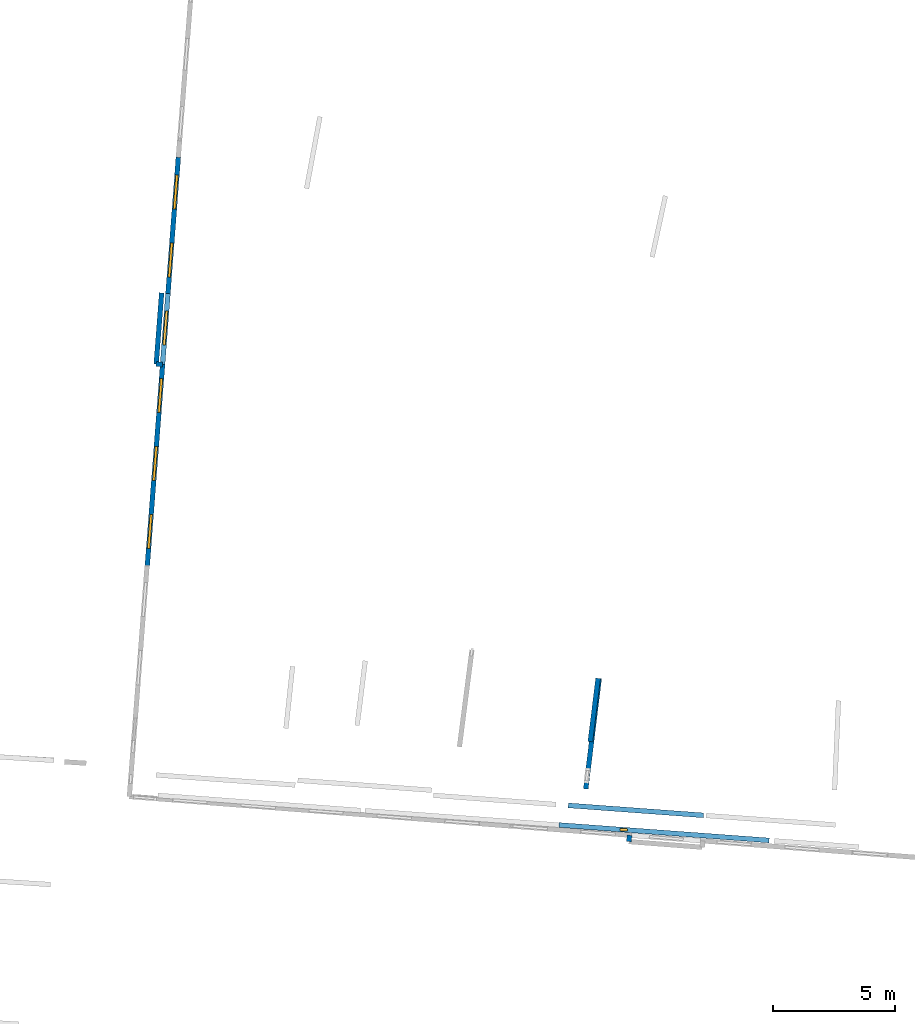
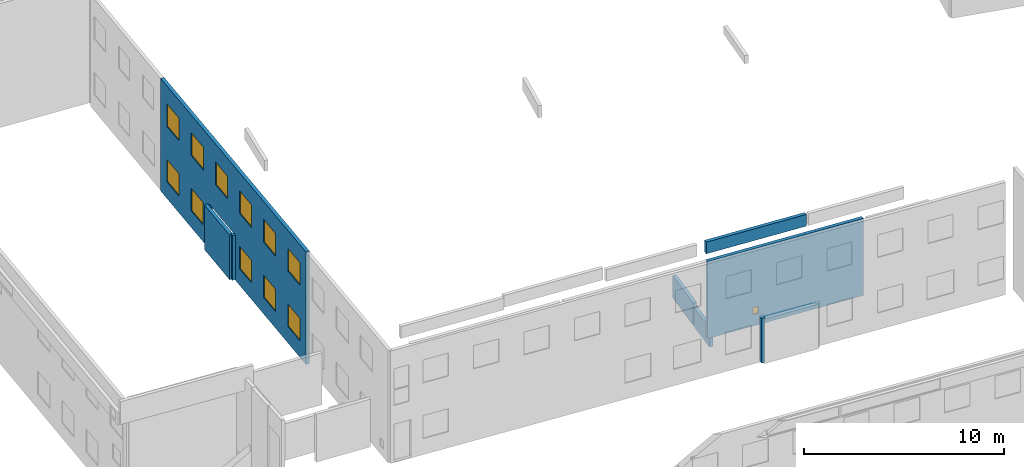
# One storey, part 14 of 27: 12 windows, 8 walls, 13 openings.
"""IFC2X3 building model written with IfcOpenShell, lengths in metres."""

from ifc_helpers import new_model, entity, si_unit, converted_unit, derived_unit, direction, frame, frame_2d, origin, origin_2d_with_axis, place, context, subcontext, project, spatial, polyline, rectangle, outline, extrude, source, transform, mapped, material, layer, layer_set, layer_usage, type_object, type_shapes, element, fill, save


model = new_model("IFC2X3")

# Units and contexts
model_context = context("Model", 3, precision=1e-05, world=origin(), true_north=direction((0.0, 1.0)))
body_context = subcontext(model_context, "Body", "Model", "MODEL_VIEW")
ifc_project = project(units=[si_unit("LENGTHUNIT", "METRE"), si_unit("AREAUNIT", "SQUARE_METRE"), si_unit("VOLUMEUNIT", "CUBIC_METRE"), converted_unit("PLANEANGLEUNIT", "DEGREE", entity("IfcRatioMeasure", 0.0174532925199433), si_unit("PLANEANGLEUNIT", "RADIAN"), dimensions=[0, 0, 0, 0, 0, 0, 0]), si_unit("MASSUNIT", "GRAM", prefix="KILO"), derived_unit("MASSDENSITYUNIT", [(si_unit("MASSUNIT", "GRAM", prefix="KILO"), 1), (si_unit("LENGTHUNIT", "METRE"), -3)]), derived_unit("MOMENTOFINERTIAUNIT", [(si_unit("LENGTHUNIT", "METRE"), 4)]), si_unit("TIMEUNIT", "SECOND"), si_unit("FREQUENCYUNIT", "HERTZ"), si_unit("THERMODYNAMICTEMPERATUREUNIT", "DEGREE_CELSIUS"), derived_unit("THERMALTRANSMITTANCEUNIT", [(si_unit("MASSUNIT", "GRAM", prefix="KILO"), 1), (si_unit("THERMODYNAMICTEMPERATUREUNIT", "KELVIN"), -1), (si_unit("TIMEUNIT", "SECOND"), -3)]), derived_unit("VOLUMETRICFLOWRATEUNIT", [(si_unit("LENGTHUNIT", "METRE"), 3), (si_unit("TIMEUNIT", "SECOND"), -1)]), si_unit("ELECTRICCURRENTUNIT", "AMPERE"), si_unit("ELECTRICVOLTAGEUNIT", "VOLT"), si_unit("POWERUNIT", "WATT"), si_unit("FORCEUNIT", "NEWTON", prefix="KILO"), si_unit("ILLUMINANCEUNIT", "LUX"), si_unit("LUMINOUSFLUXUNIT", "LUMEN"), si_unit("LUMINOUSINTENSITYUNIT", "CANDELA"), derived_unit("USERDEFINED", [(si_unit("MASSUNIT", "GRAM", prefix="KILO"), -1), (si_unit("LENGTHUNIT", "METRE"), -2), (si_unit("TIMEUNIT", "SECOND"), 3), (si_unit("LUMINOUSFLUXUNIT", "LUMEN"), 1)]), derived_unit("LINEARVELOCITYUNIT", [(si_unit("LENGTHUNIT", "METRE"), 1), (si_unit("TIMEUNIT", "SECOND"), -1)]), si_unit("PRESSUREUNIT", "PASCAL"), derived_unit("USERDEFINED", [(si_unit("LENGTHUNIT", "METRE"), -2), (si_unit("MASSUNIT", "GRAM", prefix="KILO"), 1), (si_unit("TIMEUNIT", "SECOND"), -2)]), derived_unit("LINEARFORCEUNIT", [(si_unit("MASSUNIT", "GRAM", prefix="KILO"), 1), (si_unit("LENGTHUNIT", "METRE"), 1), (si_unit("TIMEUNIT", "SECOND"), -2), (si_unit("LENGTHUNIT", "METRE"), -1)]), derived_unit("PLANARFORCEUNIT", [(si_unit("MASSUNIT", "GRAM", prefix="KILO"), 1), (si_unit("LENGTHUNIT", "METRE"), 1), (si_unit("TIMEUNIT", "SECOND"), -2), (si_unit("LENGTHUNIT", "METRE"), -2)])], contexts=[model_context])

# Site, building, storey
placement_1 = place(None, origin())
site = spatial("IfcSite", under=ifc_project, at=placement_1, CompositionType="ELEMENT")
building = spatial("IfcBuilding", under=site, at=placement_1, CompositionType="ELEMENT")
storey_placement = place(placement_1, frame((0.0, 0.0, -61.043098449707)))
storey = spatial("IfcBuildingStorey", under=building, at=storey_placement, Name="level_-61.043098", CompositionType="ELEMENT", Elevation=-61.043098449707)

# Walls
ifc_material_1 = material(Name="Default wall")
ifc_layer = layer(ifc_material_1, 0.2)
ifc_layer_set = layer_set([ifc_layer], Name="wall_thickness_0.2000")
ifc_layer_usage = layer_usage(ifc_layer_set, "AXIS2", "POSITIVE", -0.1)
wall_type = type_object("IfcWallType", Name="wall_thickness_0.2000", PredefinedType="STANDARD", material=ifc_layer_set)
wall_1_placement = place(storey_placement, frame((-69.1763557744978, 18.0980520877705, 0.0), z_axis=(0.0, 0.0, 1.0), x_axis=(-0.998143568760818, 0.060904976327205, 0.0)))
element("IfcWallStandardCase", 1, at=wall_1_placement, inside=storey, type_object=wall_type, material=ifc_layer_usage, Name="Wall:38", ObjectType="Wall", context=body_context, shape_type="SweptSolid", body=[
    extrude(outline(polyline([(0.263405559250172, -0.1), (0.263405559250172, 0.1), (0.0, 0.1), (0.0, -0.1), (0.263405559250172, -0.1)])), origin(), (0.0, 0.0, 1.0), 2.72571182250977),
])
placement_2 = place(placement_1, frame((0.0, 0.0, -54.3638687133789)))
wall_2_placement = place(placement_2, frame((-52.5274311244298, 0.00118414785496655, 0.0), z_axis=(0.0, 0.0, 1.0), x_axis=(0.997311648511455, -0.0732767066902225, 0.0)))
element("IfcWallStandardCase", 2, at=wall_2_placement, inside=storey, type_object=wall_type, material=ifc_layer_usage, Name="Wall:94", ObjectType="Wall", context=body_context, shape_type="SweptSolid", body=[
    extrude(outline(polyline([(5.56499805483768, -0.1), (5.56499805483768, 0.1), (0.0, 0.1), (0.0, -0.1), (5.56499805483768, -0.1)])), origin(), (0.0, 0.0, 1.0), 0.715465545654297),
])
wall_3_placement = place(storey_placement, frame((-50.0396073150903, -1.484275635359, 0.0), z_axis=(0.0, 0.0, 1.0), x_axis=(0.10774391964122, 0.994178680006942, 0.0)))
element("IfcWallStandardCase", 3, at=wall_3_placement, inside=storey, type_object=wall_type, material=ifc_layer_usage, Name="Wall:186", ObjectType="Wall", context=body_context, shape_type="SweptSolid", body=[
    extrude(outline(polyline([(0.264512404657137, -0.1), (0.264512404657137, 0.1), (0.0, 0.1), (0.0, -0.1), (0.264512404657137, -0.1)])), origin(), (0.0, 0.0, 1.0), 2.72571182250977),
])
placement_3 = place(placement_1, frame((0.0, 0.0, -60.7575225830078)))
wall_4_placement = place(placement_3, frame((-51.8070449313999, 0.675989727953555, 0.0), z_axis=(0.0, 0.0, 1.0), x_axis=(0.121251306889812, 0.992621841678649, 0.0)))
element("IfcWallStandardCase", 4, at=wall_4_placement, inside=storey, type_object=wall_type, material=ifc_layer_usage, Name="Wall:315", ObjectType="Wall", context=body_context, shape_type="SweptSolid", body=[
    extrude(outline(polyline([(4.5678029829579, -0.1), (4.5678029829579, 0.1), (0.0, 0.1), (0.0, -0.1), (4.5678029829579, -0.1)])), origin(), (0.0, 0.0, 1.0), 1.16252899169922),
])
wall_5_placement = place(storey_placement, frame((-69.2153692891708, 21.0358313540295, 0.0), z_axis=(0.0, 0.0, 1.0), x_axis=(-0.0764084472067439, -0.997076601468239, 0.0)))
element("IfcWallStandardCase", 5, at=wall_5_placement, inside=storey, type_object=wall_type, material=ifc_layer_usage, Name="Wall:559", ObjectType="Wall", context=body_context, shape_type="SweptSolid", body=[
    extrude(outline(polyline([(2.93030220471268, -0.1), (2.93030220471268, 0.1), (0.0, 0.1), (0.0, -0.1), (2.93030220471268, -0.1)])), origin(), (0.0, 0.0, 1.0), 2.72571182250977),
])

# Wall, opening, window
placement_4 = place(placement_1, frame((0.0, 0.0, -58.9146003723145)))
wall_6_placement = place(placement_4, frame((-52.9094965574528, -0.802554144898495, 0.0), z_axis=(0.0, 0.0, 1.0), x_axis=(0.99731400054498, -0.0732446879778095, 0.0)))
wall_6 = element("IfcWallStandardCase", 6, at=wall_6_placement, inside=storey, type_object=wall_type, material=ifc_layer_usage, Name="Wall:655", ObjectType="Wall", context=body_context, shape_type="SweptSolid", body=[
    extrude(outline(polyline([(8.65000010038955, -0.1), (8.65000010038955, 0.1), (0.0, 0.1), (0.0, -0.1), (8.65000010038955, -0.1)])), origin(), (0.0, 0.0, 1.0), 4.70542526245117),
])
opening_1_placement = place(wall_6_placement, frame((2.50999961861043, -0.1, 0.697704315185547)))
opening_1 = element("IfcOpeningElement", 7, at=opening_1_placement, cuts=wall_6, Name="Opening : 310 x 415 : 64", ObjectType="Opening", context=body_context, shape_type="SweptSolid", body=[
    extrude(rectangle(XDim=0.31, YDim=0.415, at=frame_2d((0.2075, 0.155), x_axis=(0.0, 1.0))), frame((0.0, 0.0, 0.0), z_axis=(0.0, 1.0, 0.0), x_axis=(0.0, 0.0, 1.0)), (0.0, 0.0, 1.0), 0.2),
])
ifc_material_2 = material(Name="Window Default")
window_style_1 = type_object("IfcWindowStyle", Name="Window : 310 x 415mm", ConstructionType="NOTDEFINED", OperationType="NOTDEFINED", ParameterTakesPrecedence=False, Sizeable=False, material=ifc_material_2)
shared_shape_1 = source(origin(), body_context, "Body", "SweptSolid", [
    extrude(rectangle(XDim=0.1, YDim=0.31, at=origin_2d_with_axis()), frame((0.155, 0.1, 0.0), z_axis=(0.0, 0.0, 1.0), x_axis=(0.0, 1.0, 0.0)), (0.0, 0.0, 1.0), 0.415),
])
type_shapes(window_style_1, [shared_shape_1])
window_1_placement = place(opening_1_placement, origin())
window_1 = element("IfcWindow", 8, at=window_1_placement, inside=storey, type_object=window_style_1, Name="Window : 310 x 415mm : 56", ObjectType="Window : 310 x 415mm", OverallHeight=0.415, OverallWidth=0.31, context=body_context, shape_type="MappedRepresentation", body=[
    mapped(shared_shape_1, transform((0.0, 0.0, 0.0), scale=1.0)),
])
fill(opening_1, window_1)

# Wall, openings, windows
placement_5 = place(placement_1, frame((0.0, 0.0, -61.0783157348633)))
wall_7_placement = place(placement_5, frame((-68.5301475537248, 26.599658256118, 0.0), z_axis=(0.0, 0.0, 1.0), x_axis=(-0.0757908777179765, -0.997123734977128, 0.0)))
wall_7 = element("IfcWallStandardCase", 9, at=wall_7_placement, inside=storey, type_object=wall_type, material=ifc_layer_usage, Name="Wall:1305", ObjectType="Wall", context=body_context, shape_type="SweptSolid", body=[
    extrude(outline(polyline([(16.7999758077399, -0.1), (16.7999758077399, 0.1), (0.0, 0.1), (0.0, -0.1), (16.7999758077399, -0.1)])), origin(), (0.0, 0.0, 1.0), 6.869140625),
])
opening_2_placement = place(wall_7_placement, frame((5.60997741974758, -0.1, 0.0380363464355469)))
element("IfcOpeningElement", 10, at=opening_2_placement, cuts=wall_7, Name="Opening : 2915 x 2700 : 188", ObjectType="Opening", context=body_context, shape_type="SweptSolid", body=[
    extrude(rectangle(XDim=2.915, YDim=2.7, at=frame_2d((1.35, 1.4575), x_axis=(0.0, 1.0))), frame((0.0, 0.0, 0.0), z_axis=(0.0, 1.0, 0.0), x_axis=(0.0, 0.0, 1.0)), (0.0, 0.0, 1.0), 0.2),
])
opening_3_placement = place(wall_7_placement, frame((0.724976107703026, -0.1, 4.39803695678711)))
opening_3 = element("IfcOpeningElement", 11, at=opening_3_placement, cuts=wall_7, Name="Opening : 1410 x 1385 : 189", ObjectType="Opening", context=body_context, shape_type="SweptSolid", body=[
    extrude(rectangle(XDim=1.41, YDim=1.385, at=frame_2d((0.6925, 0.705), x_axis=(0.0, 1.0))), frame((0.0, 0.0, 0.0), z_axis=(0.0, 1.0, 0.0), x_axis=(0.0, 0.0, 1.0)), (0.0, 0.0, 1.0), 0.2),
])
opening_4_placement = place(wall_7_placement, frame((3.52997622586983, -0.1, 4.39803695678711)))
opening_4 = element("IfcOpeningElement", 12, at=opening_4_placement, cuts=wall_7, Name="Opening : 1405 x 1385 : 190", ObjectType="Opening", context=body_context, shape_type="SweptSolid", body=[
    extrude(rectangle(XDim=1.405, YDim=1.385, at=frame_2d((0.6925, 0.7025), x_axis=(0.0, 1.0))), frame((0.0, 0.0, 0.0), z_axis=(0.0, 1.0, 0.0), x_axis=(0.0, 0.0, 1.0)), (0.0, 0.0, 1.0), 0.2),
])
opening_5_placement = place(wall_7_placement, frame((6.32997596329404, -0.1, 4.39303588867188)))
opening_5 = element("IfcOpeningElement", 13, at=opening_5_placement, cuts=wall_7, Name="Opening : 1395 x 1385 : 191", ObjectType="Opening", context=body_context, shape_type="SweptSolid", body=[
    extrude(rectangle(XDim=1.395, YDim=1.385, at=frame_2d((0.6925, 0.6975), x_axis=(0.0, 1.0))), frame((0.0, 0.0, 0.0), z_axis=(0.0, 1.0, 0.0), x_axis=(0.0, 0.0, 1.0)), (0.0, 0.0, 1.0), 0.2),
])
opening_6_placement = place(wall_7_placement, frame((9.10997723608747, -0.1, 4.39303588867188)))
opening_6 = element("IfcOpeningElement", 14, at=opening_6_placement, cuts=wall_7, Name="Opening : 1395 x 1385 : 192", ObjectType="Opening", context=body_context, shape_type="SweptSolid", body=[
    extrude(rectangle(XDim=1.395, YDim=1.385, at=frame_2d((0.6925, 0.6975), x_axis=(0.0, 1.0))), frame((0.0, 0.0, 0.0), z_axis=(0.0, 1.0, 0.0), x_axis=(0.0, 0.0, 1.0)), (0.0, 0.0, 1.0), 0.2),
])
opening_7_placement = place(wall_7_placement, frame((11.9049762200763, -0.1, 4.39303588867188)))
opening_7 = element("IfcOpeningElement", 15, at=opening_7_placement, cuts=wall_7, Name="Opening : 1400 x 1385 : 193", ObjectType="Opening", context=body_context, shape_type="SweptSolid", body=[
    extrude(rectangle(XDim=1.4, YDim=1.385, at=frame_2d((0.6925, 0.7), x_axis=(0.0, 1.0))), frame((0.0, 0.0, 0.0), z_axis=(0.0, 1.0, 0.0), x_axis=(0.0, 0.0, 1.0)), (0.0, 0.0, 1.0), 0.2),
])
opening_8_placement = place(wall_7_placement, frame((14.6949767251851, -0.1, 4.39803695678711)))
opening_8 = element("IfcOpeningElement", 16, at=opening_8_placement, cuts=wall_7, Name="Opening : 1405 x 1380 : 194", ObjectType="Opening", context=body_context, shape_type="SweptSolid", body=[
    extrude(rectangle(XDim=1.405, YDim=1.38, at=frame_2d((0.69, 0.7025), x_axis=(0.0, 1.0))), frame((0.0, 0.0, 0.0), z_axis=(0.0, 1.0, 0.0), x_axis=(0.0, 0.0, 1.0)), (0.0, 0.0, 1.0), 0.2),
])
opening_9_placement = place(wall_7_placement, frame((0.71997572696043, -0.1, 1.01803970336914)))
opening_9 = element("IfcOpeningElement", 17, at=opening_9_placement, cuts=wall_7, Name="Opening : 1410 x 1370 : 195", ObjectType="Opening", context=body_context, shape_type="SweptSolid", body=[
    extrude(rectangle(XDim=1.41, YDim=1.37, at=frame_2d((0.685, 0.705), x_axis=(0.0, 1.0))), frame((0.0, 0.0, 0.0), z_axis=(0.0, 1.0, 0.0), x_axis=(0.0, 0.0, 1.0)), (0.0, 0.0, 1.0), 0.2),
])
opening_10_placement = place(wall_7_placement, frame((3.51997604262315, -0.1, 1.02303695678711)))
opening_10 = element("IfcOpeningElement", 18, at=opening_10_placement, cuts=wall_7, Name="Opening : 1410 x 1365 : 196", ObjectType="Opening", context=body_context, shape_type="SweptSolid", body=[
    extrude(rectangle(XDim=1.41, YDim=1.365, at=frame_2d((0.6825, 0.705), x_axis=(0.0, 1.0))), frame((0.0, 0.0, 0.0), z_axis=(0.0, 1.0, 0.0), x_axis=(0.0, 0.0, 1.0)), (0.0, 0.0, 1.0), 0.2),
])
opening_11_placement = place(wall_7_placement, frame((9.10997723608747, -0.1, 1.00803756713867)))
opening_11 = element("IfcOpeningElement", 19, at=opening_11_placement, cuts=wall_7, Name="Opening : 1400 x 1370 : 197", ObjectType="Opening", context=body_context, shape_type="SweptSolid", body=[
    extrude(rectangle(XDim=1.4, YDim=1.37, at=frame_2d((0.685, 0.7), x_axis=(0.0, 1.0))), frame((0.0, 0.0, 0.0), z_axis=(0.0, 1.0, 0.0), x_axis=(0.0, 0.0, 1.0)), (0.0, 0.0, 1.0), 0.2),
])
opening_12_placement = place(wall_7_placement, frame((11.9049762200763, -0.1, 1.00803756713867)))
opening_12 = element("IfcOpeningElement", 20, at=opening_12_placement, cuts=wall_7, Name="Opening : 1400 x 1365 : 198", ObjectType="Opening", context=body_context, shape_type="SweptSolid", body=[
    extrude(rectangle(XDim=1.4, YDim=1.365, at=frame_2d((0.6825, 0.7), x_axis=(0.0, 1.0))), frame((0.0, 0.0, 0.0), z_axis=(0.0, 1.0, 0.0), x_axis=(0.0, 0.0, 1.0)), (0.0, 0.0, 1.0), 0.2),
])
opening_13_placement = place(wall_7_placement, frame((14.6949767251851, -0.1, 1.00803756713867)))
opening_13 = element("IfcOpeningElement", 21, at=opening_13_placement, cuts=wall_7, Name="Opening : 1400 x 1370 : 199", ObjectType="Opening", context=body_context, shape_type="SweptSolid", body=[
    extrude(rectangle(XDim=1.4, YDim=1.37, at=frame_2d((0.685, 0.7), x_axis=(0.0, 1.0))), frame((0.0, 0.0, 0.0), z_axis=(0.0, 1.0, 0.0), x_axis=(0.0, 0.0, 1.0)), (0.0, 0.0, 1.0), 0.2),
])
window_style_2 = type_object("IfcWindowStyle", Name="Window : 1400 x 1370mm", ConstructionType="NOTDEFINED", OperationType="NOTDEFINED", ParameterTakesPrecedence=False, Sizeable=False, material=ifc_material_2)
shared_shape_2 = source(origin(), body_context, "Body", "SweptSolid", [
    extrude(rectangle(XDim=0.1, YDim=1.4, at=origin_2d_with_axis()), frame((0.7, 0.1, 0.0), z_axis=(0.0, 0.0, 1.0), x_axis=(0.0, 1.0, 0.0)), (0.0, 0.0, 1.0), 1.37),
])
type_shapes(window_style_2, [shared_shape_2])
window_2_placement = place(opening_11_placement, origin())
window_2 = element("IfcWindow", 22, at=window_2_placement, inside=storey, type_object=window_style_2, Name="Window : 1400 x 1370mm : 180", ObjectType="Window : 1400 x 1370mm", OverallHeight=1.37, OverallWidth=1.4, context=body_context, shape_type="MappedRepresentation", body=[
    mapped(shared_shape_2, transform((0.0, 0.0, 0.0), scale=1.0)),
])
fill(opening_11, window_2)
window_3_placement = place(opening_13_placement, origin())
window_3 = element("IfcWindow", 23, at=window_3_placement, inside=storey, type_object=window_style_2, Name="Window : 1400 x 1370mm : 182", ObjectType="Window : 1400 x 1370mm", OverallHeight=1.37, OverallWidth=1.4, context=body_context, shape_type="MappedRepresentation", body=[
    mapped(shared_shape_2, transform((0.0, 0.0, 0.0), scale=1.0)),
])
fill(opening_13, window_3)
window_style_3 = type_object("IfcWindowStyle", Name="Window : 1400 x 1385mm", ConstructionType="NOTDEFINED", OperationType="NOTDEFINED", ParameterTakesPrecedence=False, Sizeable=False, material=ifc_material_2)
shared_shape_3 = source(origin(), body_context, "Body", "SweptSolid", [
    extrude(rectangle(XDim=0.1, YDim=1.4, at=origin_2d_with_axis()), frame((0.7, 0.1, 0.0), z_axis=(0.0, 0.0, 1.0), x_axis=(0.0, 1.0, 0.0)), (0.0, 0.0, 1.0), 1.385),
])
type_shapes(window_style_3, [shared_shape_3])
window_4_placement = place(opening_7_placement, origin())
window_4 = element("IfcWindow", 24, at=window_4_placement, inside=storey, type_object=window_style_3, Name="Window : 1400 x 1385mm : 176", ObjectType="Window : 1400 x 1385mm", OverallHeight=1.385, OverallWidth=1.4, context=body_context, shape_type="MappedRepresentation", body=[
    mapped(shared_shape_3, transform((0.0, 0.0, 0.0), scale=1.0)),
])
fill(opening_7, window_4)
window_style_4 = type_object("IfcWindowStyle", Name="Window : 1405 x 1385mm", ConstructionType="NOTDEFINED", OperationType="NOTDEFINED", ParameterTakesPrecedence=False, Sizeable=False, material=ifc_material_2)
shared_shape_4 = source(origin(), body_context, "Body", "SweptSolid", [
    extrude(rectangle(XDim=0.1, YDim=1.405, at=origin_2d_with_axis()), frame((0.7025, 0.1, 0.0), z_axis=(0.0, 0.0, 1.0), x_axis=(0.0, 1.0, 0.0)), (0.0, 0.0, 1.0), 1.385),
])
type_shapes(window_style_4, [shared_shape_4])
window_5_placement = place(opening_4_placement, origin())
window_5 = element("IfcWindow", 25, at=window_5_placement, inside=storey, type_object=window_style_4, Name="Window : 1405 x 1385mm : 173", ObjectType="Window : 1405 x 1385mm", OverallHeight=1.385, OverallWidth=1.405, context=body_context, shape_type="MappedRepresentation", body=[
    mapped(shared_shape_4, transform((0.0, 0.0, 0.0), scale=1.0)),
])
fill(opening_4, window_5)
window_style_5 = type_object("IfcWindowStyle", Name="Window : 1410 x 1370mm", ConstructionType="NOTDEFINED", OperationType="NOTDEFINED", ParameterTakesPrecedence=False, Sizeable=False, material=ifc_material_2)
shared_shape_5 = source(origin(), body_context, "Body", "SweptSolid", [
    extrude(rectangle(XDim=0.1, YDim=1.41, at=origin_2d_with_axis()), frame((0.705, 0.1, 0.0), z_axis=(0.0, 0.0, 1.0), x_axis=(0.0, 1.0, 0.0)), (0.0, 0.0, 1.0), 1.37),
])
type_shapes(window_style_5, [shared_shape_5])
window_6_placement = place(opening_9_placement, origin())
window_6 = element("IfcWindow", 26, at=window_6_placement, inside=storey, type_object=window_style_5, Name="Window : 1410 x 1370mm : 178", ObjectType="Window : 1410 x 1370mm", OverallHeight=1.37, OverallWidth=1.41, context=body_context, shape_type="MappedRepresentation", body=[
    mapped(shared_shape_5, transform((0.0, 0.0, 0.0), scale=1.0)),
])
fill(opening_9, window_6)
window_style_6 = type_object("IfcWindowStyle", Name="Window : 1410 x 1385mm", ConstructionType="NOTDEFINED", OperationType="NOTDEFINED", ParameterTakesPrecedence=False, Sizeable=False, material=ifc_material_2)
shared_shape_6 = source(origin(), body_context, "Body", "SweptSolid", [
    extrude(rectangle(XDim=0.1, YDim=1.41, at=origin_2d_with_axis()), frame((0.705, 0.1, 0.0), z_axis=(0.0, 0.0, 1.0), x_axis=(0.0, 1.0, 0.0)), (0.0, 0.0, 1.0), 1.385),
])
type_shapes(window_style_6, [shared_shape_6])
window_7_placement = place(opening_3_placement, origin())
window_7 = element("IfcWindow", 27, at=window_7_placement, inside=storey, type_object=window_style_6, Name="Window : 1410 x 1385mm : 172", ObjectType="Window : 1410 x 1385mm", OverallHeight=1.385, OverallWidth=1.41, context=body_context, shape_type="MappedRepresentation", body=[
    mapped(shared_shape_6, transform((0.0, 0.0, 0.0), scale=1.0)),
])
fill(opening_3, window_7)
window_style_7 = type_object("IfcWindowStyle", Name="Window : 1395 x 1385mm", ConstructionType="NOTDEFINED", OperationType="NOTDEFINED", ParameterTakesPrecedence=False, Sizeable=False, material=ifc_material_2)
shared_shape_7 = source(origin(), body_context, "Body", "SweptSolid", [
    extrude(rectangle(XDim=0.1, YDim=1.395, at=origin_2d_with_axis()), frame((0.6975, 0.1, 0.0), z_axis=(0.0, 0.0, 1.0), x_axis=(0.0, 1.0, 0.0)), (0.0, 0.0, 1.0), 1.385),
])
type_shapes(window_style_7, [shared_shape_7])
window_8_placement = place(opening_5_placement, origin())
window_8 = element("IfcWindow", 28, at=window_8_placement, inside=storey, type_object=window_style_7, Name="Window : 1395 x 1385mm : 174", ObjectType="Window : 1395 x 1385mm", OverallHeight=1.385, OverallWidth=1.395, context=body_context, shape_type="MappedRepresentation", body=[
    mapped(shared_shape_7, transform((0.0, 0.0, 0.0), scale=1.0)),
])
fill(opening_5, window_8)
window_9_placement = place(opening_6_placement, origin())
window_9 = element("IfcWindow", 29, at=window_9_placement, inside=storey, type_object=window_style_7, Name="Window : 1395 x 1385mm : 175", ObjectType="Window : 1395 x 1385mm", OverallHeight=1.385, OverallWidth=1.395, context=body_context, shape_type="MappedRepresentation", body=[
    mapped(shared_shape_7, transform((0.0, 0.0, 0.0), scale=1.0)),
])
fill(opening_6, window_9)
window_style_8 = type_object("IfcWindowStyle", Name="Window : 1405 x 1380mm", ConstructionType="NOTDEFINED", OperationType="NOTDEFINED", ParameterTakesPrecedence=False, Sizeable=False, material=ifc_material_2)
shared_shape_8 = source(origin(), body_context, "Body", "SweptSolid", [
    extrude(rectangle(XDim=0.1, YDim=1.405, at=origin_2d_with_axis()), frame((0.7025, 0.1, 0.0), z_axis=(0.0, 0.0, 1.0), x_axis=(0.0, 1.0, 0.0)), (0.0, 0.0, 1.0), 1.38),
])
type_shapes(window_style_8, [shared_shape_8])
window_10_placement = place(opening_8_placement, origin())
window_10 = element("IfcWindow", 30, at=window_10_placement, inside=storey, type_object=window_style_8, Name="Window : 1405 x 1380mm : 177", ObjectType="Window : 1405 x 1380mm", OverallHeight=1.38, OverallWidth=1.405, context=body_context, shape_type="MappedRepresentation", body=[
    mapped(shared_shape_8, transform((0.0, 0.0, 0.0), scale=1.0)),
])
fill(opening_8, window_10)
window_style_9 = type_object("IfcWindowStyle", Name="Window : 1410 x 1365mm", ConstructionType="NOTDEFINED", OperationType="NOTDEFINED", ParameterTakesPrecedence=False, Sizeable=False, material=ifc_material_2)
shared_shape_9 = source(origin(), body_context, "Body", "SweptSolid", [
    extrude(rectangle(XDim=0.1, YDim=1.41, at=origin_2d_with_axis()), frame((0.705, 0.1, 0.0), z_axis=(0.0, 0.0, 1.0), x_axis=(0.0, 1.0, 0.0)), (0.0, 0.0, 1.0), 1.365),
])
type_shapes(window_style_9, [shared_shape_9])
window_11_placement = place(opening_10_placement, origin())
window_11 = element("IfcWindow", 31, at=window_11_placement, inside=storey, type_object=window_style_9, Name="Window : 1410 x 1365mm : 179", ObjectType="Window : 1410 x 1365mm", OverallHeight=1.365, OverallWidth=1.41, context=body_context, shape_type="MappedRepresentation", body=[
    mapped(shared_shape_9, transform((0.0, 0.0, 0.0), scale=1.0)),
])
fill(opening_10, window_11)
window_style_10 = type_object("IfcWindowStyle", Name="Window : 1400 x 1365mm", ConstructionType="NOTDEFINED", OperationType="NOTDEFINED", ParameterTakesPrecedence=False, Sizeable=False, material=ifc_material_2)
shared_shape_10 = source(origin(), body_context, "Body", "SweptSolid", [
    extrude(rectangle(XDim=0.1, YDim=1.4, at=origin_2d_with_axis()), frame((0.7, 0.1, 0.0), z_axis=(0.0, 0.0, 1.0), x_axis=(0.0, 1.0, 0.0)), (0.0, 0.0, 1.0), 1.365),
])
type_shapes(window_style_10, [shared_shape_10])
window_12_placement = place(opening_12_placement, origin())
window_12 = element("IfcWindow", 32, at=window_12_placement, inside=storey, type_object=window_style_10, Name="Window : 1400 x 1365mm : 181", ObjectType="Window : 1400 x 1365mm", OverallHeight=1.365, OverallWidth=1.4, context=body_context, shape_type="MappedRepresentation", body=[
    mapped(shared_shape_10, transform((0.0, 0.0, 0.0), scale=1.0)),
])
fill(opening_12, window_12)

# Wall
placement_6 = place(placement_1, frame((0.0, 0.0, -60.6535377502441)))
wall_8_placement = place(placement_6, frame((-51.623070588654, 2.61912249438387, 0.0), z_axis=(0.0, 0.0, 1.0), x_axis=(0.122113822067952, 0.992516102871866, 0.0)))
element("IfcWallStandardCase", 33, at=wall_8_placement, inside=storey, type_object=wall_type, material=ifc_layer_usage, Name="Wall:1532", ObjectType="Wall", context=body_context, shape_type="SweptSolid", body=[
    extrude(outline(polyline([(2.61681728681834, -0.1), (2.61681728681834, 0.1), (0.0, 0.1), (0.0, -0.1), (2.61681728681834, -0.1)])), origin(), (0.0, 0.0, 1.0), 1.34986877441406),
])

save(model, "model.ifc")
